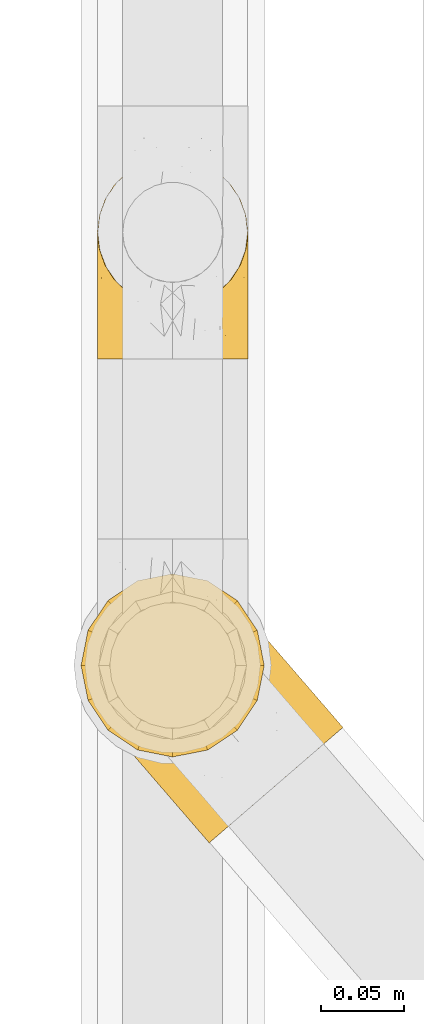
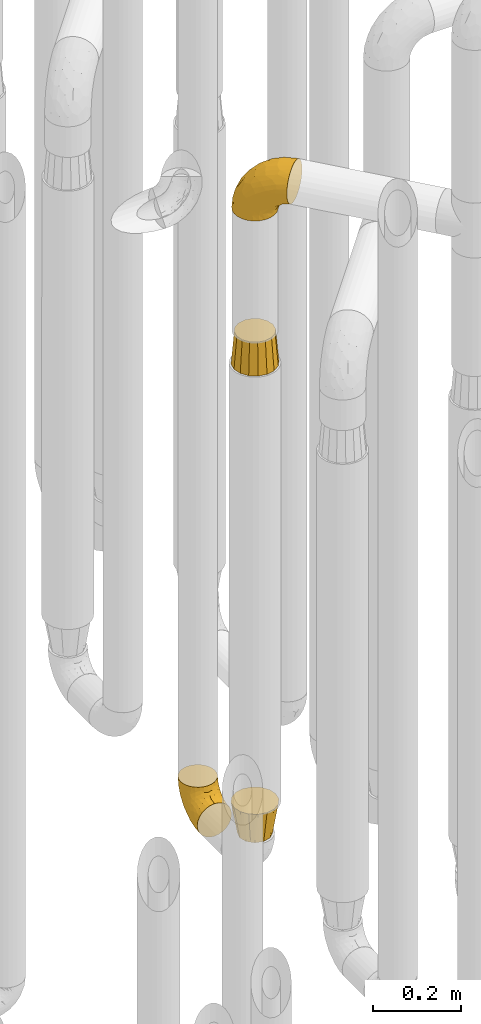
# One storey, part 214 of 827: 4 coverings.
"""IFC2X3 building model written with IfcOpenShell, lengths in millimetres."""

from ifc_helpers import new_model, entity, si_unit, converted_unit, derived_unit, direction, frame, origin, place, context, subcontext, project, spatial, faceted_brep, element, save


model = new_model("IFC2X3")

# Units and contexts
model_context = context("Model", 3, precision=0.01, world=origin(), true_north=direction((6.12303176911189e-17, 1.0)))
body_context = subcontext(model_context, "Body", "Model", "MODEL_VIEW")
ifc_project = project(units=[si_unit("LENGTHUNIT", "METRE", prefix="MILLI"), si_unit("AREAUNIT", "SQUARE_METRE"), si_unit("VOLUMEUNIT", "CUBIC_METRE"), converted_unit("PLANEANGLEUNIT", "DEGREE", entity("IfcRatioMeasure", 0.0174532925199433), si_unit("PLANEANGLEUNIT", "RADIAN"), dimensions=[0, 0, 0, 0, 0, 0, 0]), si_unit("MASSUNIT", "GRAM", prefix="KILO"), derived_unit("MASSDENSITYUNIT", [(si_unit("MASSUNIT", "GRAM", prefix="KILO"), 1), (si_unit("LENGTHUNIT", "METRE"), -3)]), derived_unit("MOMENTOFINERTIAUNIT", [(si_unit("LENGTHUNIT", "METRE"), 4)]), si_unit("TIMEUNIT", "SECOND"), si_unit("FREQUENCYUNIT", "HERTZ"), si_unit("THERMODYNAMICTEMPERATUREUNIT", "DEGREE_CELSIUS"), derived_unit("THERMALTRANSMITTANCEUNIT", [(si_unit("MASSUNIT", "GRAM", prefix="KILO"), 1), (si_unit("THERMODYNAMICTEMPERATUREUNIT", "KELVIN"), -1), (si_unit("TIMEUNIT", "SECOND"), -3)]), derived_unit("VOLUMETRICFLOWRATEUNIT", [(si_unit("LENGTHUNIT", "METRE"), 3), (si_unit("TIMEUNIT", "SECOND"), -1)]), derived_unit("MASSFLOWRATEUNIT", [(si_unit("MASSUNIT", "GRAM", prefix="KILO"), 1), (si_unit("TIMEUNIT", "SECOND"), -1)]), derived_unit("ROTATIONALFREQUENCYUNIT", [(si_unit("TIMEUNIT", "SECOND"), -1)]), si_unit("ELECTRICCURRENTUNIT", "AMPERE"), si_unit("ELECTRICVOLTAGEUNIT", "VOLT"), si_unit("POWERUNIT", "WATT"), si_unit("FORCEUNIT", "NEWTON", prefix="KILO"), si_unit("ILLUMINANCEUNIT", "LUX"), si_unit("LUMINOUSFLUXUNIT", "LUMEN"), si_unit("LUMINOUSINTENSITYUNIT", "CANDELA"), derived_unit("USERDEFINED", [(si_unit("MASSUNIT", "GRAM", prefix="KILO"), -1), (si_unit("LENGTHUNIT", "METRE"), -2), (si_unit("TIMEUNIT", "SECOND"), 3), (si_unit("LUMINOUSFLUXUNIT", "LUMEN"), 1)]), derived_unit("LINEARVELOCITYUNIT", [(si_unit("LENGTHUNIT", "METRE"), 1), (si_unit("TIMEUNIT", "SECOND"), -1)]), si_unit("PRESSUREUNIT", "PASCAL"), derived_unit("USERDEFINED", [(si_unit("LENGTHUNIT", "METRE"), -2), (si_unit("MASSUNIT", "GRAM", prefix="KILO"), 1), (si_unit("TIMEUNIT", "SECOND"), -2)]), derived_unit("LINEARFORCEUNIT", [(si_unit("MASSUNIT", "GRAM", prefix="KILO"), 1), (si_unit("LENGTHUNIT", "METRE"), 1), (si_unit("TIMEUNIT", "SECOND"), -2), (si_unit("LENGTHUNIT", "METRE"), -1)]), derived_unit("PLANARFORCEUNIT", [(si_unit("MASSUNIT", "GRAM", prefix="KILO"), 1), (si_unit("LENGTHUNIT", "METRE"), 1), (si_unit("TIMEUNIT", "SECOND"), -2), (si_unit("LENGTHUNIT", "METRE"), -2)])], contexts=[model_context])

# Site, building, storey
site_placement = place(None, origin())
site = spatial("IfcSite", under=ifc_project, at=site_placement, CompositionType="ELEMENT")
building_placement = place(site_placement, origin())
building = spatial("IfcBuilding", under=site, at=building_placement, CompositionType="ELEMENT")
storey_placement = place(building_placement, frame((0.0, 0.0, 28200.0)))
storey = spatial("IfcBuildingStorey", under=building, at=storey_placement, Name="08", CompositionType="ELEMENT", Elevation=28200.0)

# Coverings
covering_1_placement = place(storey_placement, frame((36582.9, 11912.61, 353.25)))
element("IfcCovering", 1, at=covering_1_placement, inside=storey, Name=":ADSK_", ObjectType=":ADSK_", PredefinedType="INSULATION", context=body_context, shape_type="Brep", body=[
    faceted_brep([(90.76, 87.65, 122.75), (87.42, 97.19, 122.75), (82.04, 105.75, 122.75), (74.89, 112.9, 122.75), (66.33, 118.28, 122.75), (56.79, 121.61, 122.75), (46.75, 122.75, 122.75), (36.69, 121.61, 122.75), (27.15, 118.27, 122.75), (18.59, 112.89, 122.75), (11.44, 105.74, 122.75), (6.06, 97.18, 122.75), (2.73, 87.64, 122.75), (1.6, 77.6, 122.75), (2.73, 67.54, 122.75), (6.07, 58.0, 122.75), (11.45, 49.44, 122.75), (18.6, 42.29, 122.75), (27.16, 36.91, 122.75), (36.7, 33.58, 122.75), (46.75, 32.45, 122.75), (56.8, 33.58, 122.75), (66.34, 36.92, 122.75), (74.9, 42.3, 122.75), (82.05, 49.45, 122.75), (87.43, 58.01, 122.75), (90.76, 67.55, 122.75), (91.9, 77.6, 122.75), (35.06, 1.6, 90.36), (24.17, 1.6, 85.85), (14.82, 1.6, 78.67), (7.64, 1.6, 69.32), (3.13, 1.6, 58.43), (1.6, 1.6, 46.75), (3.13, 1.6, 35.06), (7.64, 1.6, 24.17), (14.82, 1.6, 14.82), (24.17, 1.6, 7.64), (35.06, 1.6, 3.13), (46.75, 1.6, 1.6), (58.43, 1.6, 3.13), (69.32, 1.6, 7.64), (78.67, 1.6, 14.82), (85.85, 1.6, 24.17), (90.36, 1.6, 35.06), (91.9, 1.6, 46.75), (90.36, 1.6, 58.43), (85.85, 1.6, 69.32), (78.67, 1.6, 78.67), (69.32, 1.6, 85.85), (58.43, 1.6, 90.36), (46.75, 1.6, 91.9), (46.75, 99.61, 51.54), (55.2, 95.26, 47.17), (46.75, 86.21, 38.13), (46.75, 39.03, 7.52), (54.53, 30.75, 5.85), (46.75, 23.8, 5.11), (59.63, 60.8, 19.2), (62.07, 85.37, 38.98), (71.86, 73.64, 35.02), (62.65, 31.01, 8.21), (71.33, 49.14, 19.28), (72.93, 23.88, 12.19), (91.2, 82.74, 101.39), (86.31, 43.48, 34.43), (80.89, 29.47, 20.95), (79.49, 56.38, 30.74), (90.68, 72.18, 72.93), (86.84, 72.24, 56.64), (87.38, 87.6, 80.81), (76.87, 107.24, 93.43), (83.73, 101.1, 100.76), (81.03, 95.16, 74.27), (91.9, 71.81, 93.66), (91.9, 63.57, 81.33), (91.9, 55.34, 69.01), (91.03, 23.66, 40.87), (87.58, 20.55, 29.38), (56.52, 107.97, 67.05), (46.75, 116.82, 85.31), (60.4, 117.03, 93.68), (91.9, 30.68, 52.53), (91.9, 21.51, 50.71), (91.9, 12.33, 48.88), (67.87, 106.17, 72.77), (90.35, 52.37, 51.21), (69.57, 114.51, 101.18), (46.75, 119.23, 100.54), (79.91, 78.37, 48.74), (91.9, 75.46, 112.01), (91.9, 73.63, 102.83), (74.99, 101.51, 73.88), (46.75, 72.81, 24.73), (91.9, 43.01, 60.77), (88.53, 92.6, 103.08), (72.65, 91.86, 54.8), (46.75, 55.92, 16.13), (62.97, 99.01, 55.92), (46.75, 108.21, 68.42), (66.2, 32.05, 104.98), (56.6, 30.22, 108.58), (59.89, 23.37, 98.21), (90.95, 28.43, 61.56), (90.22, 16.44, 60.69), (76.64, 37.1, 100.0), (71.58, 28.88, 95.88), (79.99, 33.93, 90.81), (89.54, 50.17, 84.88), (89.97, 40.57, 73.29), (81.32, 47.62, 113.4), (74.56, 39.9, 109.8), (84.15, 47.92, 102.13), (90.37, 34.27, 67.29), (87.82, 24.65, 70.34), (90.98, 62.6, 95.15), (90.96, 66.18, 105.49), (85.14, 11.74, 71.5), (58.11, 13.89, 92.87), (46.75, 17.02, 96.03), (78.39, 15.86, 81.34), (88.22, 57.71, 107.44), (66.06, 9.11, 88.36), (68.6, 18.55, 90.43), (63.78, 34.74, 114.37), (88.42, 54.95, 98.41), (90.61, 57.35, 88.73), (83.8, 22.03, 76.89), (77.98, 24.8, 86.08), (91.22, 69.07, 112.64), (83.46, 42.31, 94.21), (46.75, 29.63, 112.22), (46.75, 28.31, 107.32), (84.66, 30.23, 79.95), (86.33, 40.13, 84.51), (46.75, 22.67, 101.67), (46.75, 12.12, 94.71), (15.1, 15.86, 81.34), (9.69, 22.03, 76.89), (15.52, 24.8, 86.08), (8.83, 30.23, 79.96), (35.39, 13.88, 92.87), (12.18, 47.61, 113.41), (1.6, 73.63, 102.83), (2.53, 66.17, 105.5), (2.27, 69.07, 112.64), (36.9, 30.22, 108.58), (27.31, 32.04, 104.98), (33.62, 23.36, 98.2), (5.07, 54.93, 98.4), (9.36, 47.91, 102.13), (5.27, 57.69, 107.44), (27.43, 9.1, 88.36), (1.6, 21.51, 50.71), (1.6, 12.33, 48.88), (10.05, 42.29, 94.22), (16.87, 37.09, 100.01), (8.35, 11.74, 71.5), (3.27, 16.44, 60.69), (1.6, 30.68, 52.53), (21.94, 28.86, 95.89), (29.72, 34.74, 114.37), (1.6, 63.57, 81.33), (1.6, 55.34, 69.01), (3.96, 50.17, 84.88), (1.6, 75.46, 112.01), (18.95, 39.89, 109.8), (2.54, 28.43, 61.56), (3.12, 34.27, 67.29), (1.6, 43.01, 60.77), (2.51, 62.59, 95.14), (3.52, 40.57, 73.29), (7.17, 40.13, 84.53), (1.6, 71.81, 93.66), (13.52, 33.92, 90.82), (2.88, 57.34, 88.73), (5.67, 24.65, 70.34), (24.89, 18.54, 90.43), (12.6, 29.47, 20.95), (7.18, 43.48, 34.43), (14.0, 56.4, 30.74), (22.16, 49.17, 19.29), (21.61, 73.69, 35.07), (3.14, 52.37, 51.21), (6.65, 72.26, 56.67), (20.82, 91.88, 54.85), (31.41, 85.36, 38.98), (5.91, 20.55, 29.38), (2.46, 23.66, 40.87), (33.87, 60.8, 19.2), (30.84, 31.02, 8.21), (38.96, 30.75, 5.85), (20.56, 23.9, 12.19), (2.81, 72.17, 72.93), (6.1, 87.59, 80.83), (2.29, 82.74, 101.39), (33.08, 117.03, 93.69), (16.61, 107.23, 93.43), (36.96, 107.97, 67.04), (9.75, 101.08, 100.76), (25.61, 106.17, 72.78), (30.5, 99.01, 55.93), (23.91, 114.5, 101.18), (12.45, 95.15, 74.27), (18.49, 101.5, 73.89), (4.96, 92.59, 103.09), (13.56, 78.38, 48.78), (38.28, 95.27, 47.19)], [[[0, 1, 2, 3, 4, 5, 6, 7, 8, 9, 10, 11, 12, 13, 14, 15, 16, 17, 18, 19, 20, 21, 22, 23, 24, 25, 26, 27]], [[28, 29, 30, 31, 32, 33, 34, 35, 36, 37, 38, 39, 40, 41, 42, 43, 44, 45, 46, 47, 48, 49, 50, 51]], [[52, 53, 54]], [[55, 56, 57]], [[58, 59, 60]], [[61, 62, 63]], [[27, 64, 0]], [[65, 66, 67]], [[41, 40, 61]], [[68, 69, 70]], [[66, 43, 42]], [[63, 42, 41]], [[71, 72, 73]], [[72, 2, 1]], [[68, 74, 75, 76]], [[45, 44, 77]], [[43, 78, 44]], [[79, 80, 81]], [[77, 82, 83, 84, 45]], [[79, 81, 85]], [[71, 2, 72]], [[65, 86, 77]], [[4, 81, 5]], [[66, 65, 78]], [[4, 3, 87]], [[81, 88, 5]], [[63, 66, 42]], [[68, 70, 64]], [[67, 60, 89]], [[71, 3, 2]], [[64, 27, 90, 91, 74]], [[92, 71, 73]], [[40, 57, 56]], [[59, 93, 54]], [[86, 76, 94, 82]], [[1, 0, 95]], [[58, 62, 61]], [[60, 96, 89]], [[85, 81, 87]], [[56, 97, 58]], [[65, 67, 69]], [[87, 81, 4]], [[67, 89, 69]], [[61, 63, 41]], [[95, 72, 1]], [[73, 72, 70]], [[69, 73, 70]], [[73, 89, 96]], [[3, 71, 87]], [[85, 87, 71]], [[58, 61, 56]], [[59, 58, 93]], [[76, 86, 68]], [[69, 89, 73]], [[68, 86, 69]], [[65, 69, 86]], [[68, 64, 74]], [[95, 64, 70]], [[98, 79, 85]], [[79, 52, 99, 80]], [[66, 62, 67]], [[62, 58, 60]], [[62, 60, 67]], [[59, 98, 96]], [[59, 96, 60]], [[96, 85, 92]], [[88, 81, 80]], [[88, 6, 5]], [[66, 63, 62]], [[64, 95, 0]], [[72, 95, 70]], [[77, 44, 78]], [[86, 82, 77]], [[40, 39, 57]], [[96, 98, 85]], [[40, 56, 61]], [[66, 78, 43]], [[77, 78, 65]], [[79, 98, 53]], [[96, 92, 73]], [[85, 71, 92]], [[97, 56, 55]], [[97, 93, 58]], [[53, 98, 59]], [[54, 53, 59]], [[79, 53, 52]], [[100, 101, 102]], [[46, 45, 84, 83]], [[103, 104, 82]], [[82, 104, 83]], [[105, 106, 107]], [[108, 109, 76]], [[110, 111, 112]], [[103, 113, 114]], [[115, 74, 116]], [[48, 47, 117]], [[118, 102, 119]], [[49, 48, 120]], [[74, 91, 116]], [[116, 121, 115]], [[49, 122, 50]], [[123, 106, 102]], [[124, 111, 22]], [[125, 126, 115]], [[23, 22, 111]], [[24, 110, 121]], [[120, 127, 128]], [[90, 26, 129]], [[27, 26, 90]], [[121, 125, 115]], [[24, 121, 25]], [[130, 105, 107]], [[129, 25, 116]], [[21, 20, 131]], [[120, 123, 122]], [[112, 105, 130]], [[50, 118, 51]], [[21, 124, 22]], [[101, 131, 132]], [[117, 120, 48]], [[24, 23, 110]], [[127, 114, 133]], [[75, 108, 76]], [[107, 134, 130]], [[133, 114, 113]], [[129, 116, 91]], [[25, 121, 116]], [[121, 112, 125]], [[75, 74, 115]], [[101, 135, 102]], [[131, 101, 21]], [[101, 100, 124]], [[128, 127, 133]], [[119, 136, 51, 118]], [[104, 47, 46]], [[83, 104, 46]], [[117, 104, 114]], [[101, 124, 21]], [[111, 124, 100]], [[102, 118, 123]], [[133, 134, 107]], [[111, 110, 23]], [[114, 104, 103]], [[94, 76, 109]], [[121, 110, 112]], [[122, 118, 50]], [[134, 109, 108]], [[133, 107, 128]], [[112, 108, 125]], [[126, 125, 108]], [[108, 75, 126]], [[75, 115, 126]], [[109, 134, 133]], [[130, 108, 112]], [[108, 130, 134]], [[105, 112, 111]], [[111, 100, 105]], [[106, 105, 100]], [[102, 106, 100]], [[128, 106, 123]], [[90, 129, 91]], [[25, 129, 26]], [[104, 117, 47]], [[117, 114, 127]], [[82, 94, 103]], [[113, 94, 109]], [[94, 113, 103]], [[133, 113, 109]], [[106, 128, 107]], [[123, 120, 128]], [[120, 122, 49]], [[118, 122, 123]], [[135, 101, 132]], [[135, 119, 102]], [[117, 127, 120]], [[30, 29, 137]], [[138, 139, 140]], [[51, 136, 119, 141]], [[142, 17, 16]], [[143, 144, 145]], [[146, 147, 148]], [[149, 150, 151]], [[152, 29, 28]], [[33, 32, 153, 154]], [[150, 155, 156]], [[157, 31, 30]], [[153, 158, 159]], [[29, 152, 137]], [[148, 141, 119]], [[156, 160, 147]], [[148, 135, 146]], [[137, 138, 157]], [[19, 161, 146]], [[162, 163, 164]], [[14, 13, 165]], [[153, 32, 158]], [[147, 161, 166]], [[18, 17, 166]], [[167, 168, 169]], [[166, 150, 156]], [[151, 150, 142]], [[151, 170, 149]], [[151, 16, 15]], [[171, 140, 172]], [[165, 143, 145]], [[173, 170, 144]], [[142, 166, 17]], [[19, 131, 20]], [[144, 170, 151]], [[18, 161, 19]], [[173, 144, 143]], [[140, 139, 174]], [[171, 164, 163]], [[164, 172, 155]], [[151, 15, 144]], [[145, 15, 14]], [[173, 162, 170]], [[149, 175, 164]], [[19, 146, 131]], [[132, 131, 146]], [[160, 148, 147]], [[159, 158, 167]], [[135, 132, 146]], [[158, 32, 31]], [[157, 158, 31]], [[167, 158, 176]], [[166, 161, 18]], [[146, 161, 147]], [[148, 177, 141]], [[171, 168, 140]], [[171, 163, 169]], [[151, 142, 16]], [[166, 142, 150]], [[152, 141, 177]], [[51, 141, 28]], [[138, 140, 176]], [[172, 140, 174]], [[175, 149, 170]], [[164, 150, 149]], [[170, 162, 175]], [[162, 164, 175]], [[155, 172, 174]], [[171, 172, 164]], [[155, 174, 156]], [[164, 155, 150]], [[160, 156, 174]], [[147, 166, 156]], [[139, 160, 174]], [[148, 160, 177]], [[15, 145, 144]], [[165, 145, 14]], [[137, 157, 30]], [[158, 157, 176]], [[168, 167, 176]], [[169, 159, 167]], [[140, 168, 176]], [[169, 168, 171]], [[137, 177, 139]], [[160, 139, 177]], [[141, 152, 28]], [[137, 152, 177]], [[148, 119, 135]], [[157, 138, 176]], [[139, 138, 137]], [[178, 179, 180]], [[181, 180, 182]], [[179, 183, 184]], [[185, 186, 182]], [[187, 188, 179]], [[188, 33, 154, 153, 159]], [[181, 189, 190]], [[35, 34, 187]], [[191, 38, 190]], [[192, 178, 181]], [[179, 184, 180]], [[192, 190, 37]], [[37, 190, 38]], [[36, 35, 178]], [[54, 93, 186]], [[35, 187, 178]], [[193, 194, 184]], [[195, 173, 143, 165, 13]], [[195, 193, 173]], [[193, 163, 162, 173]], [[13, 12, 195]], [[8, 7, 196]], [[9, 197, 10]], [[198, 80, 99, 52]], [[196, 7, 88]], [[197, 199, 10]], [[182, 189, 181]], [[200, 198, 201]], [[200, 196, 198]], [[9, 8, 202]], [[194, 199, 203]], [[192, 37, 36]], [[80, 196, 88]], [[183, 159, 169, 163]], [[188, 34, 33]], [[202, 200, 197]], [[185, 203, 204]], [[202, 8, 196]], [[10, 199, 11]], [[12, 11, 205]], [[38, 191, 57]], [[189, 97, 191]], [[203, 199, 197]], [[205, 199, 194]], [[204, 203, 197]], [[184, 203, 206]], [[200, 202, 196]], [[197, 9, 202]], [[207, 54, 186]], [[97, 55, 191]], [[194, 203, 184]], [[183, 163, 193]], [[184, 206, 180]], [[183, 193, 184]], [[205, 195, 12]], [[193, 195, 194]], [[80, 198, 196]], [[207, 186, 201]], [[182, 180, 206]], [[181, 178, 180]], [[185, 182, 206]], [[182, 186, 189]], [[203, 185, 206]], [[185, 200, 201]], [[7, 6, 88]], [[178, 192, 36]], [[190, 192, 181]], [[199, 205, 11]], [[195, 205, 194]], [[159, 183, 188]], [[179, 188, 183]], [[57, 191, 55]], [[57, 39, 38]], [[189, 191, 190]], [[188, 187, 34]], [[178, 187, 179]], [[186, 93, 189]], [[197, 200, 204]], [[185, 204, 200]], [[189, 93, 97]], [[207, 198, 52]], [[185, 201, 186]], [[198, 207, 201]], [[54, 207, 52]]]),
])
covering_2_placement = place(storey_placement, frame((36575.14, 11622.03, 2208.4)))
element("IfcCovering", 2, at=covering_2_placement, inside=storey, Name=":ADSK_", ObjectType=":ADSK_", PredefinedType="INSULATION", context=body_context, shape_type="Brep", body=[
    faceted_brep([(125.52, 43.98, 148.32), (116.59, 36.27, 149.65), (107.66, 28.55, 148.31), (99.17, 21.22, 144.39), (91.55, 14.64, 138.06), (85.2, 9.15, 129.66), (80.42, 5.03, 119.6), (77.45, 2.46, 108.39), (76.44, 1.6, 96.6), (77.45, 2.47, 84.79), (80.42, 5.03, 73.57), (85.21, 9.16, 63.51), (91.57, 14.66, 55.11), (99.18, 21.23, 48.79), (107.67, 28.56, 44.87), (116.59, 36.27, 43.55), (125.53, 43.99, 44.88), (134.02, 51.32, 48.8), (141.63, 57.89, 55.13), (147.99, 63.38, 63.53), (152.77, 67.51, 73.59), (155.74, 70.07, 84.8), (156.75, 70.94, 96.6), (155.74, 70.07, 108.41), (152.77, 67.51, 119.62), (147.98, 63.37, 129.68), (141.62, 57.88, 138.08), (134.01, 51.31, 144.4), (77.6, 60.41, 1.6), (64.46, 56.06, 1.6), (50.63, 55.26, 1.6), (37.07, 58.07, 1.6), (24.7, 64.29, 1.6), (14.35, 73.5, 1.6), (6.75, 85.07, 1.6), (2.4, 98.22, 1.6), (1.6, 112.04, 1.6), (4.4, 125.6, 1.6), (10.62, 137.98, 1.6), (19.83, 148.32, 1.6), (31.4, 155.93, 1.6), (44.55, 160.28, 1.6), (58.38, 161.08, 1.6), (71.94, 158.27, 1.6), (84.31, 152.05, 1.6), (94.65, 142.84, 1.6), (102.26, 131.27, 1.6), (106.61, 118.12, 1.6), (107.41, 104.3, 1.6), (104.61, 90.73, 1.6), (98.39, 78.36, 1.6), (89.18, 68.02, 1.6), (51.35, 159.08, 27.97), (39.18, 154.64, 37.09), (55.45, 151.65, 58.27), (29.11, 152.23, 27.13), (23.13, 144.5, 39.91), (103.88, 115.37, 109.11), (85.23, 131.82, 94.41), (83.2, 120.56, 110.94), (53.69, 134.69, 89.69), (32.79, 133.31, 75.62), (48.17, 115.5, 106.28), (88.29, 143.75, 60.12), (76.96, 152.95, 41.41), (79.95, 146.72, 63.22), (85.72, 149.73, 32.05), (96.08, 139.8, 52.13), (105.4, 103.03, 123.27), (95.19, 99.22, 129.32), (114.54, 79.42, 138.3), (45.82, 147.85, 62.95), (34.36, 146.02, 55.89), (65.46, 156.85, 37.4), (91.55, 65.27, 144.6), (105.35, 73.91, 142.66), (68.92, 112.37, 117.85), (83.78, 91.71, 134.01), (96.7, 129.82, 89.25), (139.67, 89.32, 103.34), (135.16, 89.67, 113.52), (106.51, 129.11, 57.43), (102.1, 134.22, 44.19), (97.69, 139.32, 30.95), (105.59, 127.69, 77.98), (125.53, 80.92, 132.66), (122.95, 94.37, 121.52), (67.61, 138.68, 86.93), (71.95, 147.11, 68.4), (120.25, 113.2, 78.45), (113.38, 121.16, 67.94), (148.22, 80.81, 94.53), (137.56, 93.16, 91.95), (123.03, 108.59, 93.36), (128.9, 103.18, 85.2), (115.3, 112.48, 101.45), (68.21, 92.29, 129.81), (96.17, 141.08, 16.27), (118.48, 68.28, 42.46), (117.39, 80.68, 40.4), (124.87, 82.47, 49.71), (107.56, 125.69, 39.4), (109.79, 117.53, 31.26), (104.7, 128.74, 27.7), (101.82, 132.81, 16.7), (129.35, 99.09, 70.67), (137.5, 91.76, 81.69), (107.25, 118.91, 16.68), (92.85, 63.76, 22.57), (91.39, 65.45, 14.26), (100.01, 75.47, 17.68), (109.23, 100.97, 19.58), (113.57, 100.48, 33.49), (113.23, 89.81, 33.01), (113.14, 57.4, 40.69), (108.32, 45.85, 40.15), (102.89, 52.14, 37.93), (106.11, 70.25, 31.04), (116.74, 106.75, 45.29), (107.53, 85.3, 23.55), (103.59, 85.72, 11.36), (117.8, 113.29, 59.1), (124.29, 99.09, 57.42), (122.27, 109.37, 68.96), (109.18, 110.81, 20.38), (140.85, 82.29, 72.46), (146.48, 80.83, 83.66), (132.44, 84.4, 60.66), (139.38, 71.66, 61.01), (130.26, 69.79, 51.85), (124.47, 57.4, 46.07), (97.87, 57.95, 30.25), (112.36, 118.65, 46.65), (118.78, 92.23, 43.0), (53.66, 52.98, 19.58), (67.54, 18.98, 72.44), (80.23, 58.39, 17.67), (39.95, 43.86, 78.45), (43.44, 41.3, 68.97), (52.58, 32.81, 70.65), (96.2, 42.77, 40.69), (84.68, 39.07, 42.45), (84.52, 51.59, 31.04), (60.94, 42.26, 42.99), (46.79, 46.46, 45.18), (53.57, 48.61, 33.46), (66.68, 27.61, 60.64), (53.33, 37.82, 57.37), (26.21, 59.76, 57.43), (21.8, 64.87, 44.19), (29.45, 58.23, 39.35), (15.87, 71.74, 16.27), (23.23, 64.95, 16.7), (57.26, 23.81, 91.95), (48.6, 33.84, 85.2), (58.62, 23.7, 81.68), (35.65, 52.49, 46.68), (37.2, 54.84, 31.26), (36.2, 57.54, 16.68), (26.84, 61.5, 27.7), (78.28, 18.89, 60.99), (81.46, 27.64, 51.84), (72.56, 41.94, 40.41), (69.68, 34.8, 49.72), (94.56, 31.56, 46.06), (67.92, 11.47, 94.53), (69.57, 56.33, 11.35), (64.16, 47.39, 33.02), (68.16, 13.2, 83.65), (43.93, 54.46, 20.38), (33.08, 51.81, 67.94), (69.4, 52.38, 23.53), (40.2, 46.3, 59.12), (17.39, 69.98, 30.95), (11.35, 113.57, 58.27), (4.6, 118.71, 27.97), (4.75, 104.42, 37.4), (6.93, 92.48, 41.41), (14.62, 139.7, 27.21), (10.76, 130.1, 37.09), (19.3, 134.39, 53.2), (17.15, 71.64, 52.13), (60.74, 21.17, 103.34), (61.06, 25.67, 113.5), (41.39, 48.65, 101.45), (26.63, 81.21, 94.41), (40.18, 60.34, 109.08), (38.07, 81.55, 110.95), (44.1, 40.43, 93.36), (27.75, 60.47, 77.98), (8.84, 83.34, 32.05), (17.31, 122.48, 64.63), (52.16, 57.06, 123.25), (71.11, 33.91, 132.65), (57.44, 66.58, 129.32), (79.2, 38.73, 139.96), (48.25, 94.52, 117.85), (28.38, 112.84, 89.69), (58.2, 38.41, 121.51), (12.66, 88.61, 63.23), (26.89, 69.61, 89.17), (80.98, 52.86, 142.66), (13.44, 96.59, 68.4), (22.41, 99.65, 86.94), (14.38, 79.93, 60.12), (64.39, 75.17, 133.2)], [[[0, 1, 2, 3, 4, 5, 6, 7, 8, 9, 10, 11, 12, 13, 14, 15, 16, 17, 18, 19, 20, 21, 22, 23, 24, 25, 26, 27]], [[28, 29, 30, 31, 32, 33, 34, 35, 36, 37, 38, 39, 40, 41, 42, 43, 44, 45, 46, 47, 48, 49, 50, 51]], [[52, 53, 54]], [[55, 39, 56]], [[57, 58, 59]], [[60, 61, 62]], [[63, 64, 65]], [[66, 63, 67]], [[68, 69, 70]], [[53, 71, 54]], [[41, 40, 53]], [[53, 72, 71]], [[73, 42, 52]], [[42, 41, 52]], [[74, 0, 75]], [[69, 76, 77]], [[43, 73, 64]], [[45, 44, 66]], [[57, 78, 58]], [[23, 79, 80]], [[67, 81, 82, 83]], [[67, 84, 81]], [[24, 23, 80]], [[25, 85, 26]], [[86, 85, 25]], [[42, 73, 43]], [[0, 27, 75]], [[25, 24, 86]], [[70, 26, 85]], [[0, 74, 1]], [[68, 85, 86]], [[66, 64, 63]], [[60, 59, 87]], [[54, 87, 88]], [[76, 60, 62]], [[84, 89, 90, 81]], [[79, 22, 91, 92]], [[77, 74, 75]], [[93, 92, 94, 89]], [[80, 86, 24]], [[40, 55, 53]], [[76, 59, 60]], [[93, 84, 95]], [[76, 62, 96]], [[55, 72, 53]], [[70, 27, 26]], [[75, 70, 69]], [[78, 84, 63]], [[93, 79, 92]], [[95, 86, 80]], [[77, 76, 96]], [[59, 69, 68]], [[57, 68, 86]], [[68, 57, 59]], [[59, 58, 87]], [[76, 69, 59]], [[88, 87, 58]], [[87, 54, 71]], [[86, 95, 57]], [[78, 57, 95]], [[84, 78, 95]], [[78, 63, 65]], [[58, 78, 65]], [[54, 88, 73]], [[84, 93, 89]], [[79, 95, 80]], [[79, 93, 95]], [[22, 79, 23]], [[66, 83, 97, 45]], [[84, 67, 63]], [[83, 66, 67]], [[64, 44, 43]], [[64, 66, 44]], [[65, 73, 88]], [[53, 52, 41]], [[73, 52, 54]], [[73, 65, 64]], [[65, 88, 58]], [[39, 55, 40]], [[72, 55, 56]], [[56, 61, 72]], [[60, 72, 61]], [[72, 60, 71]], [[87, 71, 60]], [[27, 70, 75]], [[68, 70, 85]], [[74, 77, 96]], [[69, 77, 75]], [[98, 99, 100]], [[46, 45, 97]], [[101, 102, 103]], [[103, 104, 83]], [[105, 94, 106]], [[107, 103, 102]], [[108, 109, 51, 110]], [[111, 112, 113]], [[114, 115, 116]], [[47, 104, 107]], [[110, 117, 108]], [[49, 48, 111]], [[102, 118, 112]], [[119, 120, 111]], [[50, 49, 120]], [[121, 122, 118]], [[105, 123, 89]], [[124, 48, 107]], [[20, 19, 125]], [[121, 81, 90]], [[117, 119, 99]], [[21, 20, 126]], [[22, 21, 91]], [[105, 125, 127]], [[110, 51, 50]], [[19, 128, 125]], [[16, 15, 115]], [[129, 98, 100]], [[126, 91, 21]], [[128, 129, 127]], [[122, 123, 105]], [[114, 117, 98]], [[17, 16, 130]], [[18, 128, 19]], [[129, 18, 17]], [[125, 106, 126]], [[115, 114, 16]], [[130, 129, 17]], [[114, 98, 130]], [[117, 116, 131, 108]], [[99, 119, 113]], [[122, 121, 123]], [[92, 126, 106]], [[105, 127, 122]], [[132, 121, 118]], [[114, 130, 16]], [[129, 130, 98]], [[50, 120, 110]], [[129, 128, 18]], [[125, 128, 127]], [[125, 126, 20]], [[91, 126, 92]], [[105, 89, 94]], [[105, 106, 125]], [[94, 92, 106]], [[100, 122, 127]], [[118, 122, 133]], [[112, 118, 133]], [[132, 118, 102]], [[132, 102, 101]], [[81, 121, 132]], [[82, 103, 83]], [[132, 101, 81]], [[104, 47, 46]], [[124, 107, 102]], [[48, 47, 107]], [[113, 112, 133]], [[112, 111, 124]], [[99, 113, 133]], [[111, 113, 119]], [[99, 133, 100]], [[117, 99, 98]], [[122, 100, 133]], [[127, 129, 100]], [[103, 82, 101]], [[81, 101, 82]], [[112, 124, 102]], [[48, 124, 111]], [[104, 103, 107]], [[46, 97, 104]], [[111, 120, 49]], [[83, 104, 97]], [[110, 120, 119]], [[117, 110, 119]], [[116, 117, 114]], [[89, 123, 90]], [[90, 123, 121]], [[30, 29, 134]], [[11, 10, 135]], [[51, 109, 108, 136]], [[137, 138, 139]], [[140, 141, 142]], [[143, 144, 145]], [[146, 139, 147]], [[148, 149, 150]], [[151, 32, 152]], [[153, 154, 155]], [[156, 150, 157]], [[158, 157, 159]], [[108, 142, 136]], [[31, 158, 152]], [[160, 161, 12]], [[162, 163, 143]], [[140, 142, 116]], [[142, 141, 162]], [[14, 164, 140]], [[14, 140, 115]], [[9, 8, 165]], [[160, 12, 11]], [[141, 164, 161]], [[13, 12, 161]], [[14, 115, 15]], [[28, 166, 29]], [[135, 139, 146]], [[141, 163, 162]], [[135, 146, 160]], [[143, 167, 162]], [[29, 166, 134]], [[116, 142, 108, 131]], [[165, 153, 168]], [[10, 9, 168]], [[168, 135, 10]], [[138, 147, 139]], [[158, 169, 157]], [[14, 13, 164]], [[116, 115, 140]], [[145, 167, 143]], [[135, 160, 11]], [[168, 153, 155]], [[138, 137, 170]], [[157, 144, 156]], [[147, 144, 143]], [[161, 164, 13]], [[140, 164, 141]], [[142, 171, 136]], [[136, 171, 166]], [[161, 160, 146]], [[165, 168, 9]], [[155, 139, 135]], [[139, 154, 137]], [[168, 155, 135]], [[139, 155, 154]], [[144, 147, 172]], [[163, 147, 143]], [[156, 144, 172]], [[157, 169, 145]], [[172, 148, 156]], [[173, 159, 149]], [[159, 157, 150]], [[152, 159, 173]], [[159, 152, 158]], [[31, 30, 158]], [[169, 30, 134]], [[157, 145, 144]], [[167, 134, 171]], [[134, 167, 145]], [[171, 142, 162]], [[162, 167, 171]], [[163, 141, 161]], [[161, 146, 163]], [[147, 163, 146]], [[148, 150, 156]], [[149, 159, 150]], [[30, 169, 158]], [[145, 169, 134]], [[151, 33, 32]], [[31, 152, 32]], [[152, 173, 151]], [[28, 51, 136]], [[134, 166, 171]], [[28, 136, 166]], [[138, 170, 172]], [[147, 138, 172]], [[148, 172, 170]], [[174, 175, 176]], [[35, 34, 177]], [[178, 179, 180]], [[181, 173, 149, 148]], [[182, 183, 184]], [[185, 186, 187]], [[188, 189, 137]], [[190, 33, 151, 173]], [[191, 179, 174]], [[34, 190, 177]], [[39, 38, 178]], [[192, 193, 194]], [[4, 3, 195]], [[175, 179, 37]], [[38, 37, 179]], [[35, 176, 36]], [[196, 62, 197]], [[181, 190, 173]], [[37, 36, 175]], [[183, 6, 198]], [[189, 148, 170, 137]], [[185, 199, 200]], [[3, 2, 201]], [[202, 185, 203]], [[8, 7, 182]], [[200, 184, 186]], [[183, 7, 6]], [[181, 189, 204]], [[200, 189, 184]], [[5, 198, 6]], [[187, 203, 185]], [[195, 3, 201]], [[205, 196, 194]], [[62, 61, 197]], [[186, 198, 192]], [[180, 179, 191]], [[2, 1, 74]], [[198, 193, 192]], [[193, 5, 4]], [[194, 193, 195]], [[2, 74, 201]], [[5, 193, 198]], [[205, 74, 96]], [[188, 137, 154, 153]], [[62, 196, 96]], [[56, 178, 180]], [[198, 184, 183]], [[184, 188, 182]], [[203, 197, 191]], [[205, 194, 201]], [[187, 192, 194]], [[192, 187, 186]], [[194, 196, 187]], [[197, 187, 196]], [[197, 203, 187]], [[202, 174, 176]], [[200, 186, 185]], [[184, 198, 186]], [[199, 185, 202]], [[189, 200, 204]], [[174, 202, 203]], [[176, 177, 199]], [[189, 181, 148]], [[190, 181, 204]], [[190, 204, 177]], [[190, 34, 33]], [[188, 153, 182]], [[189, 188, 184]], [[182, 153, 165, 8]], [[183, 182, 7]], [[199, 177, 204]], [[35, 177, 176]], [[176, 175, 36]], [[179, 175, 174]], [[200, 199, 204]], [[176, 199, 202]], [[203, 191, 174]], [[180, 197, 61]], [[197, 180, 191]], [[61, 56, 180]], [[39, 178, 56]], [[38, 179, 178]], [[194, 195, 201]], [[4, 195, 193]], [[74, 205, 201]], [[96, 196, 205]]]),
])
covering_3_placement = place(storey_placement, frame((36573.05, 11673.61, 1781.0)))
element("IfcCovering", 3, at=covering_3_placement, inside=storey, Name=":ADSK_", ObjectType=":ADSK_", PredefinedType="INSULATION", context=body_context, shape_type="Brep", body=[
    faceted_brep([(35.55, 107.41, 0.0), (43.51, 108.99, 0.0), (56.6, 111.6, 0.0), (69.69, 108.99, 0.0), (77.64, 107.41, 0.0), (86.56, 101.45, 0.0), (95.49, 95.49, 0.0), (101.45, 86.56, 0.0), (107.41, 77.64, 0.0), (108.99, 69.69, 0.0), (111.6, 56.6, 0.0), (108.99, 43.51, 0.0), (107.41, 35.55, 0.0), (101.45, 26.63, 0.0), (95.49, 17.7, 0.0), (86.56, 11.74, 0.0), (77.64, 5.78, 0.0), (69.69, 4.2, 0.0), (56.6, 1.6, 0.0), (43.51, 4.2, 0.0), (35.55, 5.78, 0.0), (26.63, 11.74, 0.0), (17.7, 17.7, 0.0), (11.74, 26.63, 0.0), (5.78, 35.55, 0.0), (4.2, 43.51, 0.0), (1.6, 56.6, 0.0), (4.2, 69.69, 0.0), (5.78, 77.64, 0.0), (11.74, 86.56, 0.0), (17.7, 95.49, 0.0), (26.63, 101.45, 0.0), (9.1, 56.6, 89.0), (10.9, 47.51, 89.0), (12.71, 38.42, 89.0), (17.86, 30.71, 89.0), (23.01, 23.01, 89.0), (30.71, 17.86, 89.0), (38.42, 12.71, 89.0), (47.51, 10.9, 89.0), (56.6, 9.1, 89.0), (65.68, 10.9, 89.0), (74.77, 12.71, 89.0), (82.48, 17.86, 89.0), (90.18, 23.01, 89.0), (95.33, 30.71, 89.0), (100.48, 38.42, 89.0), (102.29, 47.51, 89.0), (104.1, 56.6, 89.0), (102.29, 65.68, 89.0), (100.48, 74.77, 89.0), (95.33, 82.48, 89.0), (90.18, 90.18, 89.0), (82.48, 95.33, 89.0), (74.77, 100.48, 89.0), (65.68, 102.29, 89.0), (56.6, 104.1, 89.0), (47.51, 102.29, 89.0), (38.42, 100.48, 89.0), (30.71, 95.33, 89.0), (23.01, 90.18, 89.0), (17.86, 82.48, 89.0), (12.71, 74.77, 89.0), (10.9, 65.68, 89.0)], [[[0, 1, 2, 3, 4, 5, 6, 7, 8, 9, 10, 11, 12, 13, 14, 15, 16, 17, 18, 19, 20, 21, 22, 23, 24, 25, 26, 27, 28, 29, 30, 31]], [[32, 33, 34, 35, 36, 37, 38, 39, 40, 41, 42, 43, 44, 45, 46, 47, 48, 49, 50, 51, 52, 53, 54, 55, 56, 57, 58, 59, 60, 61, 62, 63]], [[46, 12, 11, 10, 48, 47]], [[44, 14, 13, 12, 46, 45]], [[42, 16, 15, 14, 44, 43]], [[41, 40, 18, 17, 16, 42]], [[38, 20, 19, 18, 40, 39]], [[36, 22, 21, 20, 38, 37]], [[34, 24, 23, 22, 36, 35]], [[33, 32, 26, 25, 24, 34]], [[62, 28, 27, 26, 32, 63]], [[60, 30, 29, 28, 62, 61]], [[58, 0, 31, 30, 60, 59]], [[57, 56, 2, 1, 0, 58]], [[54, 4, 3, 2, 56, 55]], [[52, 6, 5, 4, 54, 53]], [[50, 8, 7, 6, 52, 51]], [[49, 48, 10, 9, 8, 50]]]),
])
covering_4_placement = place(storey_placement, frame((36573.05, 11673.61, 476.0)))
element("IfcCovering", 4, at=covering_4_placement, inside=storey, Name=":ADSK_", ObjectType=":ADSK_", PredefinedType="INSULATION", context=body_context, shape_type="Brep", body=[
    faceted_brep([(17.7, 95.49, 89.0), (11.74, 86.56, 89.0), (5.78, 77.64, 89.0), (3.69, 67.12, 89.0), (1.6, 56.6, 89.0), (3.69, 46.07, 89.0), (5.78, 35.55, 89.0), (11.74, 26.63, 89.0), (17.7, 17.7, 89.0), (26.63, 11.74, 89.0), (35.55, 5.78, 89.0), (46.07, 3.69, 89.0), (56.6, 1.6, 89.0), (67.12, 3.69, 89.0), (77.64, 5.78, 89.0), (86.56, 11.74, 89.0), (95.49, 17.7, 89.0), (101.45, 26.63, 89.0), (107.41, 35.55, 89.0), (109.5, 46.07, 89.0), (111.6, 56.6, 89.0), (109.5, 67.12, 89.0), (107.41, 77.64, 89.0), (101.45, 86.56, 89.0), (95.49, 95.49, 89.0), (86.56, 101.45, 89.0), (77.64, 107.41, 89.0), (67.12, 109.5, 89.0), (56.6, 111.6, 89.0), (46.07, 109.5, 89.0), (35.55, 107.41, 89.0), (26.63, 101.45, 89.0), (91.24, 76.6, 0.0), (93.92, 66.6, 0.0), (96.6, 56.6, 0.0), (93.92, 46.6, 0.0), (91.24, 36.6, 0.0), (83.92, 29.27, 0.0), (76.6, 21.95, 0.0), (66.6, 19.27, 0.0), (56.6, 16.6, 0.0), (46.6, 19.27, 0.0), (36.6, 21.95, 0.0), (29.27, 29.27, 0.0), (21.95, 36.6, 0.0), (19.27, 46.6, 0.0), (16.6, 56.6, 0.0), (19.27, 66.6, 0.0), (21.95, 76.6, 0.0), (29.27, 83.92, 0.0), (36.6, 91.24, 0.0), (46.6, 93.92, 0.0), (56.6, 96.6, 0.0), (66.6, 93.92, 0.0), (76.6, 91.24, 0.0), (83.92, 83.92, 0.0)], [[[0, 1, 2, 3, 4, 5, 6, 7, 8, 9, 10, 11, 12, 13, 14, 15, 16, 17, 18, 19, 20, 21, 22, 23, 24, 25, 26, 27, 28, 29, 30, 31]], [[32, 33, 34, 35, 36, 37, 38, 39, 40, 41, 42, 43, 44, 45, 46, 47, 48, 49, 50, 51, 52, 53, 54, 55]], [[21, 20, 34]], [[54, 25, 55]], [[55, 23, 32]], [[34, 33, 21]], [[24, 55, 25]], [[54, 26, 25]], [[23, 55, 24]], [[52, 27, 53]], [[23, 22, 32]], [[33, 32, 22]], [[27, 52, 28]], [[26, 54, 53]], [[27, 26, 53]], [[33, 22, 21]], [[29, 28, 52]], [[48, 1, 49]], [[49, 31, 50]], [[52, 51, 29]], [[0, 49, 1]], [[48, 2, 1]], [[31, 49, 0]], [[46, 3, 47]], [[31, 30, 50]], [[51, 50, 30]], [[3, 46, 4]], [[2, 48, 47]], [[3, 2, 47]], [[51, 30, 29]], [[5, 4, 46]], [[42, 9, 43]], [[43, 7, 44]], [[46, 45, 5]], [[8, 43, 9]], [[42, 10, 9]], [[7, 43, 8]], [[40, 11, 41]], [[7, 6, 44]], [[45, 44, 6]], [[11, 40, 12]], [[10, 42, 41]], [[11, 10, 41]], [[45, 6, 5]], [[13, 12, 40]], [[36, 17, 37]], [[37, 15, 38]], [[40, 39, 13]], [[16, 37, 17]], [[36, 18, 17]], [[15, 37, 16]], [[34, 19, 35]], [[15, 14, 38]], [[39, 38, 14]], [[19, 34, 20]], [[18, 36, 35]], [[19, 18, 35]], [[39, 14, 13]]]),
])

save(model, "model.ifc")
